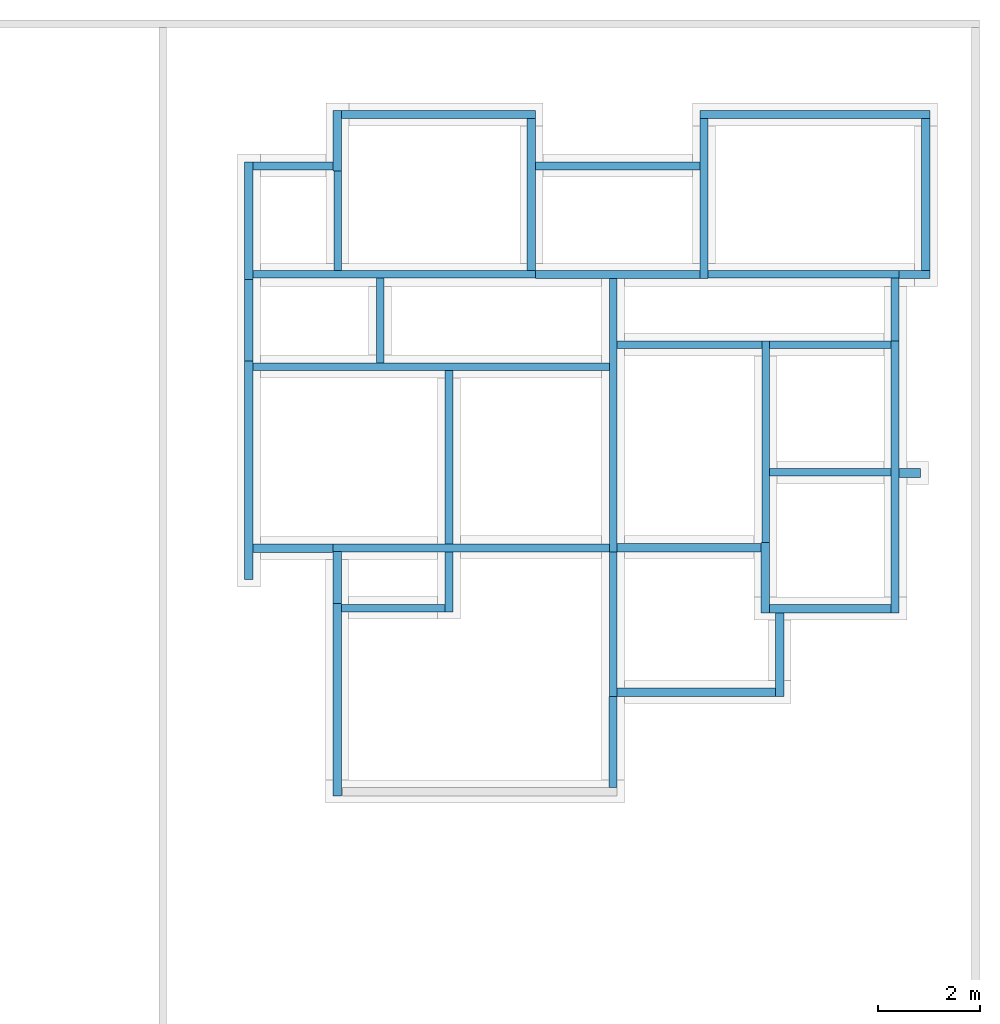
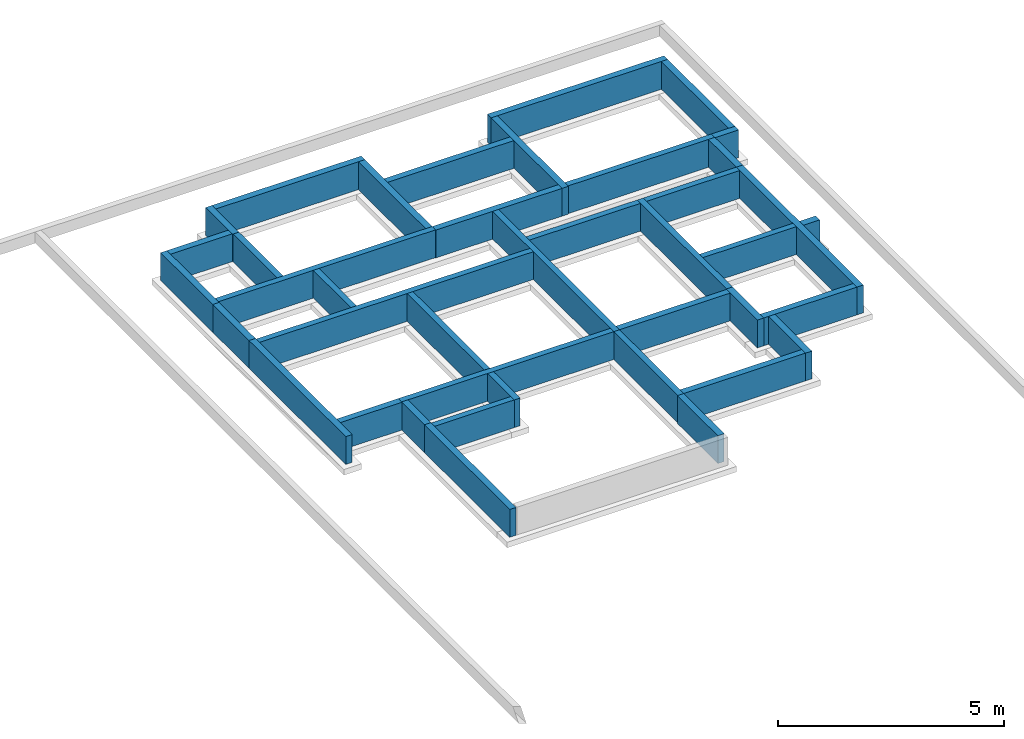
# One storey, part 2 of 2: 40 walls.
"""IFC4 building model written with IfcOpenShell, lengths in millimetres."""

from ifc_helpers import new_model, entity, si_unit, converted_unit, frame, origin_with_axes, origin_2d_with_axis, place, context, subcontext, project, spatial, indexed_curve, outline, extrude, material, layer, layer_set, layer_usage, type_object, element, save


model = new_model("IFC4")

# Units and contexts
model_context = context("Model", 3, precision=1e-05, world=origin_with_axes())
plan_context = context("Plan", 2, precision=1e-05, world=origin_2d_with_axis())
body_context = subcontext(model_context, "Body", "Model", "MODEL_VIEW")
ifc_project = project(units=[si_unit("LENGTHUNIT", "METRE", prefix="MILLI"), converted_unit("PLANEANGLEUNIT", "degree", entity("IfcReal", 0.0174532925199433), si_unit("PLANEANGLEUNIT", "RADIAN"), dimensions=[0, 0, 0, 0, 0, 0, 0]), si_unit("AREAUNIT", "SQUARE_METRE"), si_unit("VOLUMEUNIT", "CUBIC_METRE")], contexts=[model_context, plan_context])

# Site, building, storey
site_placement = place(None, origin_with_axes())
site = spatial("IfcSite", under=ifc_project, at=site_placement)
building_placement = place(site_placement, origin_with_axes())
building = spatial("IfcBuilding", under=site, at=building_placement, Name="Building")
storey_placement = place(building_placement, frame((0.0, 0.0, -900.000035762787), z_axis=(0.0, 0.0, 1.0), x_axis=(1.0, 0.0, 0.0)))
storey = spatial("IfcBuildingStorey", under=building, at=storey_placement, Name="FOUNDATION PLAN")

# Walls
ifc_material_1 = material(Name="Paint", Category="Surface Finishes")
ifc_layer_1 = layer(ifc_material_1, 1.0, Name="1-Paint", Category="Finish", Priority=4)
ifc_material_2 = material(Name="Render - Mortar", Category="Surface Finishes")
ifc_layer_2 = layer(ifc_material_2, 12.5, Name="2-Render Mortar", Category="Substrate", Priority=2)
ifc_material_3 = material(Category="Masonry")
ifc_layer_3 = layer(ifc_material_3, 150.0, Name="3", Priority=1)
ifc_layer_4 = layer(ifc_material_2, 12.5, Name="4-Plaster", Category="Substrate", Priority=2)
ifc_material_4 = material(Name="Plaster - Gypsum", Category="Surface Finishes")
ifc_layer_5 = layer(ifc_material_4, 3.0, Name="5-Plaster", Category="Finish", Priority=5)
ifc_layer_6 = layer(ifc_material_1, 1.0, Name="6-Paint", Category="Finish", Priority=5)
ifc_layer_set_1 = layer_set([ifc_layer_1, ifc_layer_2, ifc_layer_3, ifc_layer_4, ifc_layer_5, ifc_layer_6])
ifc_layer_usage_1 = layer_usage(ifc_layer_set_1, "AXIS2", "POSITIVE", 0.0)
wall_type_1 = type_object("IfcWallType", Name="WAL150HOL_2Pnt", PredefinedType="USERDEFINED", material=ifc_layer_set_1)
wall_1_placement = place(storey_placement, frame((13018.2762145996, 8947.99900054932, 1.11022302462516e-13), z_axis=(0.0, 0.0, 1.0), x_axis=(-0.999999999999803, 6.27832946520233e-07, 0.0)))
element("IfcWall", 1, at=wall_1_placement, inside=storey, type_object=wall_type_1, material=ifc_layer_usage_1, Name="WAL150HOL_2Pnt", context=body_context, shape_type="SweptSolid", body=[
    extrude(outline(indexed_curve([(0.0, 0.0), (0.0, 180.0), (420.001035814187, 180.0), (420.001035814187, 0.0), (0.0, 0.0)], self_intersect=False)), origin_with_axes(), (0.0, 0.0, 1.0), 750.000059604645),
])
ifc_material_5 = material(Category="Masonry")
ifc_layer_7 = layer(ifc_material_5, 150.0, Priority=1)
ifc_layer_set_2 = layer_set([ifc_layer_7], Name="WAL-SLD-CRE-1LYR")
ifc_layer_usage_2 = layer_usage(ifc_layer_set_2, "AXIS2", "POSITIVE", 0.0)
wall_type_2 = type_object("IfcWallType", Name="WAL150SLD_CRE", PredefinedType="SOLIDWALL", material=ifc_layer_set_2)
wall_2_placement = place(storey_placement, frame((3855.96919059753, 7463.68026733398, 1.11022302462516e-13), z_axis=(0.0, 0.0, 1.0), x_axis=(3.13916473260163e-07, 0.999999999999951, 0.0)))
element("IfcWall", 2, at=wall_2_placement, inside=storey, type_object=wall_type_2, material=ifc_layer_usage_2, Name="WAL150HOL_2Pnt", context=body_context, shape_type="SweptSolid", body=[
    extrude(outline(indexed_curve([(0.0, 0.0), (0.0, 150.0), (3404.64394879872, 150.0), (3404.64394879872, 0.0), (0.0, 0.0)], self_intersect=False)), origin_with_axes(), (0.0, 0.0, 1.0), 750.000059604645),
])
ifc_layer_usage_3 = layer_usage(ifc_layer_set_2, "AXIS2", "POSITIVE", 0.0)
wall_3_placement = place(storey_placement, frame((1523.79846572876, 14773.9343643188, 0.0), z_axis=(0.0, 0.0, 1.0), x_axis=(-6.39757843145941e-07, -0.999999999999795, 0.0)))
element("IfcWall", 3, at=wall_3_placement, inside=storey, type_object=wall_type_2, material=ifc_layer_usage_3, Name="WAL125HOL_2Pnt", context=body_context, shape_type="SweptSolid", body=[
    extrude(outline(indexed_curve([(0.0, 0.0), (0.0, 150.0), (1945.60147632466, 150.0), (1945.60147632466, 0.0), (0.0, 0.0)], self_intersect=False)), origin_with_axes(), (0.0, 0.0, 1.0), 750.000059604645),
])
ifc_layer_usage_4 = layer_usage(ifc_layer_set_2, "AXIS2", "POSITIVE", 0.0)
wall_4_placement = place(storey_placement, frame((5473.26993942261, 12828.3309936523, 0.0), z_axis=(0.0, 0.0, 1.0), x_axis=(-0.999999999999924, 3.89414367418765e-07, 0.0)))
element("IfcWall", 4, at=wall_4_placement, inside=storey, type_object=wall_type_2, material=ifc_layer_usage_4, Name="WAL150HOL_2Pnt", context=body_context, shape_type="SweptSolid", body=[
    extrude(outline(indexed_curve([(0.0, 0.0), (0.0, 150.0), (5533.79909592729, 150.0), (5533.79909592729, 0.0), (0.0, 0.0)], self_intersect=False)), origin_with_axes(), (0.0, 0.0, 1.0), 750.000059604645),
])
ifc_layer_usage_5 = layer_usage(ifc_layer_set_2, "AXIS2", "POSITIVE", 0.0)
wall_5_placement = place(storey_placement, frame((6923.27165603638, 12664.831161499, 1.11022302462516e-13), z_axis=(0.0, 0.0, 1.0), x_axis=(-1.11659494450508e-06, -0.999999999999377, 0.0)))
element("IfcWall", 5, at=wall_5_placement, inside=storey, type_object=wall_type_2, material=ifc_layer_usage_5, Name="WAL150HOL_2Pnt", context=body_context, shape_type="SweptSolid", body=[
    extrude(outline(indexed_curve([(0.0, 0.0), (0.0, 150.0), (5350.32454602854, 150.0), (5350.32454602854, 0.0), (0.0, 0.0)], self_intersect=False)), origin_with_axes(), (0.0, 0.0, 1.0), 750.000059604645),
])
ifc_layer_usage_6 = layer_usage(ifc_layer_set_2, "AXIS2", "POSITIVE", 0.0)
wall_6_placement = place(storey_placement, frame((10056.7636489868, 8798.00224304199, 1.11022302462516e-13), z_axis=(0.0, 0.0, 1.0), x_axis=(0.999999999999289, -1.19209289550697e-06, 0.0)))
element("IfcWall", 6, at=wall_6_placement, inside=storey, type_object=wall_type_2, material=ifc_layer_usage_6, Name="WAL125SLD_2Til", context=body_context, shape_type="SweptSolid", body=[
    extrude(outline(indexed_curve([(0.0, 0.0), (0.0, 150.0), (2378.01460882288, 150.0), (2378.01460882288, 0.0), (0.0, 0.0)], self_intersect=False)), origin_with_axes(), (0.0, 0.0, 1.0), 750.000059604645),
])
ifc_layer_usage_7 = layer_usage(ifc_layer_set_2, "AXIS2", "POSITIVE", 0.0)
wall_7_placement = place(storey_placement, frame((7073.27127456665, 11298.3283996582, 1.11022302462516e-13), z_axis=(0.0, 0.0, 1.0), x_axis=(0.999999999998799, -1.5497207641583e-06, 0.0)))
element("IfcWall", 7, at=wall_7_placement, inside=storey, type_object=wall_type_2, material=ifc_layer_usage_7, Name="WAL125HOL_2Pnt", context=body_context, shape_type="SweptSolid", body=[
    extrude(outline(indexed_curve([(0.0, 0.0), (0.0, 150.0), (2833.49369568034, 150.0), (2833.49369568034, 0.0), (0.0, 0.0)], self_intersect=False)), origin_with_axes(), (0.0, 0.0, 1.0), 750.000059604645),
])
ifc_layer_usage_8 = layer_usage(ifc_layer_set_2, "AXIS2", "POSITIVE", 0.0)
wall_8_placement = place(storey_placement, frame((9906.76498413086, 11448.3242034912, 1.11022302462516e-13), z_axis=(0.0, 0.0, 1.0), x_axis=(-6.39757843145941e-07, -0.999999999999795, 0.0)))
element("IfcWall", 8, at=wall_8_placement, inside=storey, type_object=wall_type_2, material=ifc_layer_usage_8, Name="WAL125SLD_IntTil", context=body_context, shape_type="SweptSolid", body=[
    extrude(outline(indexed_curve([(0.0, 0.0), (0.0, 150.0), (3953.32619377569, 150.0), (3953.32619377569, 0.0), (0.0, 0.0)], self_intersect=False)), origin_with_axes(), (0.0, 0.0, 1.0), 750.000059604645),
])
ifc_layer_usage_9 = layer_usage(ifc_layer_set_2, "AXIS2", "POSITIVE", 0.0)
wall_9_placement = place(storey_placement, frame((10056.7646026611, 11298.3226776123, 1.11022302462516e-13), z_axis=(0.0, 0.0, 1.0), x_axis=(0.999999999999744, -7.15255737304505e-07, 0.0)))
element("IfcWall", 9, at=wall_9_placement, inside=storey, type_object=wall_type_2, material=ifc_layer_usage_9, Name="WAL125SLD_IntTil", context=body_context, shape_type="SweptSolid", body=[
    extrude(outline(indexed_curve([(0.0, 0.0), (0.0, 150.0), (2378.01551115734, 150.0), (2378.01551115734, 0.0), (0.0, 0.0)], self_intersect=False)), origin_with_axes(), (0.0, 0.0, 1.0), 750.000059604645),
])
ifc_layer_usage_10 = layer_usage(ifc_layer_set_2, "AXIS2", "POSITIVE", 0.0)
wall_10_placement = place(storey_placement, frame((1673.49863052368, 6137.1808052063, 1.11022302462516e-13), z_axis=(0.0, 0.0, 1.0), x_axis=(1.0, 0.0, 0.0)))
element("IfcWall", 10, at=wall_10_placement, inside=storey, type_object=wall_type_2, material=ifc_layer_usage_10, Name="WAL125SLD_IntTil", context=body_context, shape_type="SweptSolid", body=[
    extrude(outline(indexed_curve([(0.0, 0.0), (0.0, 150.0), (2032.4709230715, 150.0), (2032.4709230715, 0.0), (0.0, 0.0)], self_intersect=False)), origin_with_axes(), (0.0, 0.0, 1.0), 750.000059604645),
])
ifc_layer_usage_11 = layer_usage(ifc_layer_set_2, "AXIS2", "POSITIVE", 0.0)
wall_11_placement = place(storey_placement, frame((6923.26593399048, 7463.68026733398, 1.11022302462516e-13), z_axis=(0.0, 0.0, 1.0), x_axis=(-0.999999999999989, 1.50995802528085e-07, 0.0)))
element("IfcWall", 11, at=wall_11_placement, inside=storey, type_object=wall_type_2, material=ifc_layer_usage_11, Name="WAL125SLD_IntTil", context=body_context, shape_type="SweptSolid", body=[
    extrude(outline(indexed_curve([(0.0, 0.0), (0.0, 150.0), (5413.26660647562, 150.0), (5413.26660647562, 0.0), (0.0, 0.0)], self_intersect=False)), origin_with_axes(), (0.0, 0.0, 1.0), 750.000059604645),
])
ifc_layer_usage_12 = layer_usage(ifc_layer_set_2, "AXIS2", "POSITIVE", 0.0)
wall_12_placement = place(storey_placement, frame((3855.96942901611, 6137.1808052063, 1.11022302462516e-13), z_axis=(0.0, 0.0, 1.0), x_axis=(3.13916473260163e-07, 0.999999999999951, 0.0)))
element("IfcWall", 12, at=wall_12_placement, inside=storey, type_object=wall_type_2, material=ifc_layer_usage_12, Name="WAL125SLD_IntTil", context=body_context, shape_type="SweptSolid", body=[
    extrude(outline(indexed_curve([(0.0, 0.0), (0.0, 150.0), (1176.49986637382, 150.0), (1176.49986637382, 0.0), (0.0, 0.0)], self_intersect=False)), origin_with_axes(), (0.0, 0.0, 1.0), 750.000059604645),
])
ifc_layer_usage_13 = layer_usage(ifc_layer_set_2, "AXIS2", "POSITIVE", 0.0)
wall_13_placement = place(storey_placement, frame((12598.2828140259, 12828.3252716064, 0.0), z_axis=(0.0, 0.0, 1.0), x_axis=(-0.999999999999625, 8.66251525621595e-07, 0.0)))
element("IfcWall", 13, at=wall_13_placement, inside=storey, type_object=wall_type_2, material=ifc_layer_usage_13, Name="WAL150HOL_2Pnt", context=body_context, shape_type="SweptSolid", body=[
    extrude(outline(indexed_curve([(0.0, 0.0), (0.0, 150.0), (3741.78406008133, 150.0), (3741.78406008133, 0.0), (0.0, 0.0)], self_intersect=False)), origin_with_axes(), (0.0, 0.0, 1.0), 750.000059604645),
])
ifc_layer_usage_14 = layer_usage(ifc_layer_set_2, "AXIS2", "POSITIVE", 0.0)
wall_14_placement = place(storey_placement, frame((-60.5289898812771, 10868.3319091797, 1.11022302462516e-13), z_axis=(0.0, 0.0, 1.0), x_axis=(0.999999999998799, -1.5497207641583e-06, 0.0)))
element("IfcWall", 14, at=wall_14_placement, inside=storey, type_object=wall_type_2, material=ifc_layer_usage_14, Name="WAL150HOL_2Pnt", context=body_context, shape_type="SweptSolid", body=[
    extrude(outline(indexed_curve([(0.0, 0.0), (0.0, 150.0), (6983.79848755728, 150.0), (6983.79848755728, 0.0), (0.0, 0.0)], self_intersect=False)), origin_with_axes(), (0.0, 0.0, 1.0), 750.000059604645),
])
ifc_layer_usage_15 = layer_usage(ifc_layer_set_2, "AXIS2", "POSITIVE", 0.0)
wall_15_placement = place(storey_placement, frame((2505.97023963928, 11018.3267593384, 0.0), z_axis=(0.0, 0.0, 1.0), x_axis=(3.13916473260163e-07, 0.999999999999951, 0.0)))
element("IfcWall", 15, at=wall_15_placement, inside=storey, type_object=wall_type_2, material=ifc_layer_usage_15, Name="WAL125SLD_IntTil", context=body_context, shape_type="SweptSolid", body=[
    extrude(outline(indexed_curve([(0.0, 0.0), (0.0, 150.0), (1660.0045886609, 150.0), (1660.0045886609, 0.0), (0.0, 0.0)], self_intersect=False)), origin_with_axes(), (0.0, 0.0, 1.0), 750.000059604645),
])
ifc_layer_usage_16 = layer_usage(ifc_layer_set_2, "AXIS2", "POSITIVE", 0.0)
wall_16_placement = place(storey_placement, frame((7073.26126098633, 4480.18360137939, 1.11022302462516e-13), z_axis=(0.0, 0.0, 1.0), x_axis=(1.5060094256097e-06, 0.999999999998866, 0.0)))
element("IfcWall", 16, at=wall_16_placement, inside=storey, type_object=wall_type_2, material=ifc_layer_usage_16, Name="WAL150HOL_2Pnt", context=body_context, shape_type="SweptSolid", body=[
    extrude(outline(indexed_curve([(0.0, 0.0), (0.0, 150.0), (2834.32389689906, 150.0), (2834.32389689906, 0.0), (0.0, 0.0)], self_intersect=False)), origin_with_axes(), (0.0, 0.0, 1.0), 750.000059604645),
])
ifc_material_6 = material(Name="Paint", Category="Surface Finishes")
ifc_layer_8 = layer(ifc_material_6, 1.0, Name="1-Paint", Category="Finish", Priority=4)
ifc_material_7 = material(Name="Render - Mortar", Category="Surface Finishes")
ifc_layer_9 = layer(ifc_material_7, 12.5, Name="2-Render Mortar", Category="Substrate", Priority=2)
ifc_layer_10 = layer(ifc_material_5, 150.0, Name="3", Priority=1)
ifc_layer_set_3 = layer_set([ifc_layer_8, ifc_layer_9, ifc_layer_10], Name="WAL-SLD-PNT-3LYR")
ifc_layer_usage_17 = layer_usage(ifc_layer_set_3, "AXIS2", "POSITIVE", 0.0)
wall_type_3 = type_object("IfcWallType", PredefinedType="SOLIDWALL", material=ifc_layer_set_3)
wall_17_placement = place(storey_placement, frame((13198.2774734497, 12828.3243179321, 0.0), z_axis=(0.0, 0.0, 1.0), x_axis=(6.71544341912371e-07, 0.999999999999775, 0.0)))
element("IfcWall", 17, at=wall_17_placement, inside=storey, type_object=wall_type_3, material=ifc_layer_usage_17, Name="WAL150HOL_2Pnt", context=body_context, shape_type="SweptSolid", body=[
    extrude(outline(indexed_curve([(0.0, 0.0), (0.0, 163.5), (2970.95592258397, 163.5), (2970.95592258397, 0.0), (0.0, 0.0)], self_intersect=False)), origin_with_axes(), (0.0, 0.0, 1.0), 750.000059604645),
])
ifc_layer_usage_18 = layer_usage(ifc_layer_set_3, "AXIS2", "POSITIVE", 0.0)
wall_18_placement = place(storey_placement, frame((1510.29884815216, 15962.7857208252, 1.11022302462516e-13), z_axis=(0.0, 0.0, 1.0), x_axis=(-6.39757843145941e-07, -0.999999999999795, 0.0)))
element("IfcWall", 18, at=wall_18_placement, inside=storey, type_object=wall_type_3, material=ifc_layer_usage_18, Name="WAL150SLD_IntTil", context=body_context, shape_type="SweptSolid", body=[
    extrude(outline(indexed_curve([(0.0, 0.0), (0.0, 163.5), (1188.85134051421, 163.5), (1188.85134051421, 0.0), (0.0, 0.0)], self_intersect=False)), origin_with_axes(), (0.0, 0.0, 1.0), 750.000059604645),
])
ifc_layer_usage_19 = layer_usage(ifc_layer_set_3, "AXIS2", "POSITIVE", 0.0)
wall_19_placement = place(storey_placement, frame((1510.29801368713, 14953.9346694946, 0.0), z_axis=(0.0, 0.0, 1.0), x_axis=(-0.999999999999924, 3.89414367418765e-07, 0.0)))
element("IfcWall", 19, at=wall_19_placement, inside=storey, type_object=wall_type_3, material=ifc_layer_usage_19, Name="WAL150HOL_2Pnt", context=body_context, shape_type="SweptSolid", body=[
    extrude(outline(indexed_curve([(0.0, 0.0), (0.0, 163.5), (1570.82650801253, 163.5), (1570.82650801253, 0.0), (0.0, 0.0)], self_intersect=False)), origin_with_axes(), (0.0, 0.0, 1.0), 750.000059604645),
])
ifc_layer_usage_20 = layer_usage(ifc_layer_set_3, "AXIS2", "POSITIVE", 0.0)
wall_20_placement = place(storey_placement, frame((12598.2828140259, 12664.8254394531, 0.0), z_axis=(0.0, 0.0, 1.0), x_axis=(0.999999999999545, -9.53674316405816e-07, 0.0)))
element("IfcWall", 20, at=wall_20_placement, inside=storey, type_object=wall_type_3, material=ifc_layer_usage_20, Name="WAL150HOL_2Pnt", context=body_context, shape_type="SweptSolid", body=[
    extrude(outline(indexed_curve([(0.0, 0.0), (0.0, 163.5), (599.994647479782, 163.5), (599.994647479782, 0.0), (0.0, 0.0)], self_intersect=False)), origin_with_axes(), (0.0, 0.0, 1.0), 750.000059604645),
])
ifc_layer_usage_21 = layer_usage(ifc_layer_set_3, "AXIS2", "POSITIVE", 0.0)
wall_21_placement = place(storey_placement, frame((5473.27184677124, 15962.7828598022, 1.11022302462516e-13), z_axis=(0.0, 0.0, 1.0), x_axis=(-0.999999999999803, 6.27832946520233e-07, 0.0)))
element("IfcWall", 21, at=wall_21_placement, inside=storey, type_object=wall_type_3, material=ifc_layer_usage_21, Name="WAL150SLD_IntTil", context=body_context, shape_type="SweptSolid", body=[
    extrude(outline(indexed_curve([(0.0, 0.0), (0.0, 163.5), (3799.47275218395, 163.5), (3799.47275218395, 0.0), (0.0, 0.0)], self_intersect=False)), origin_with_axes(), (0.0, 0.0, 1.0), 750.000059604645),
])
ifc_layer_usage_22 = layer_usage(ifc_layer_set_3, "AXIS2", "POSITIVE", 0.0)
wall_22_placement = place(storey_placement, frame((13198.2793807983, 15962.7799987793, 0.0), z_axis=(0.0, 0.0, 1.0), x_axis=(-0.999999999999803, 6.27832946520233e-07, 0.0)))
element("IfcWall", 22, at=wall_22_placement, inside=storey, type_object=wall_type_3, material=ifc_layer_usage_22, Name="WAL150HOL_2Pnt", context=body_context, shape_type="SweptSolid", body=[
    extrude(outline(indexed_curve([(0.0, 0.0), (0.0, 163.5), (4505.27856437703, 163.5), (4505.27856437703, 0.0), (0.0, 0.0)], self_intersect=False)), origin_with_axes(), (0.0, 0.0, 1.0), 750.000059604645),
])
ifc_layer_usage_23 = layer_usage(ifc_layer_set_3, "AXIS2", "POSITIVE", 0.0)
wall_23_placement = place(storey_placement, frame((-224.028423428535, 14953.9356231689, 1.11022302462516e-13), z_axis=(0.0, 0.0, 1.0), x_axis=(-2.82129974493717e-07, -0.99999999999996, 0.0)))
element("IfcWall", 23, at=wall_23_placement, inside=storey, type_object=wall_type_3, material=ifc_layer_usage_23, Name="WAL150HOL_2Pnt", context=body_context, shape_type="SweptSolid", body=[
    extrude(outline(indexed_curve([(0.0, 0.0), (0.0, 163.5), (2305.93589980149, 163.5), (2305.93589980149, 0.0), (0.0, 0.0)], self_intersect=False)), origin_with_axes(), (0.0, 0.0, 1.0), 750.000059604645),
])
ifc_layer_usage_24 = layer_usage(ifc_layer_set_3, "AXIS2", "POSITIVE", 0.0)
wall_24_placement = place(storey_placement, frame((5473.26993942261, 12828.3309936523, 0.0), z_axis=(0.0, 0.0, 1.0), x_axis=(6.71544341912371e-07, 0.999999999999775, 0.0)))
element("IfcWall", 24, at=wall_24_placement, inside=storey, type_object=wall_type_3, material=ifc_layer_usage_24, Name="WAL150SLD_IntTil.001", context=body_context, shape_type="SweptSolid", body=[
    extrude(outline(indexed_curve([(0.0, 0.0), (0.0, 163.5), (2970.95207059171, 163.5), (2970.95207059171, 0.0), (0.0, 0.0)], self_intersect=False)), origin_with_axes(), (0.0, 0.0, 1.0), 750.000059604645),
])
ifc_layer_usage_25 = layer_usage(ifc_layer_set_3, "AXIS2", "POSITIVE", 0.0)
wall_25_placement = place(storey_placement, frame((-224.029079079628, 12647.9997634888, 0.0), z_axis=(0.0, 0.0, 1.0), x_axis=(-2.82129974493717e-07, -0.99999999999996, 0.0)))
element("IfcWall", 25, at=wall_25_placement, inside=storey, type_object=wall_type_3, material=ifc_layer_usage_25, Name="WAL150SLD_IntTil", context=body_context, shape_type="SweptSolid", body=[
    extrude(outline(indexed_curve([(0.0, 0.0), (0.0, 163.5), (1599.66757718545, 163.5), (1599.66757718545, 0.0), (0.0, 0.0)], self_intersect=False)), origin_with_axes(), (0.0, 0.0, 1.0), 750.000059604645),
])
ifc_layer_usage_26 = layer_usage(ifc_layer_set_3, "AXIS2", "POSITIVE", 0.0)
wall_26_placement = place(storey_placement, frame((7073.26650619507, 7314.50653076172, 1.11022302462516e-13), z_axis=(0.0, 0.0, 1.0), x_axis=(0.999999999999886, -4.76837158203071e-07, 0.0)))
element("IfcWall", 26, at=wall_26_placement, inside=storey, type_object=wall_type_3, material=ifc_layer_usage_26, Name="WAL150HOL_2Pnt", context=body_context, shape_type="SweptSolid", body=[
    extrude(outline(indexed_curve([(0.0, 0.0), (0.0, 163.5), (2819.996316786, 163.5), (2819.996316786, 0.0), (0.0, 0.0)], self_intersect=False)), origin_with_axes(), (0.0, 0.0, 1.0), 750.000059604645),
])
ifc_layer_usage_27 = layer_usage(ifc_layer_set_3, "AXIS2", "POSITIVE", 0.0)
wall_27_placement = place(storey_placement, frame((-224.029511213303, 11048.3322143555, 0.0), z_axis=(0.0, 0.0, 1.0), x_axis=(-2.82129974493717e-07, -0.99999999999996, 0.0)))
element("IfcWall", 27, at=wall_27_placement, inside=storey, type_object=wall_type_3, material=ifc_layer_usage_27, Name="WAL150HOL_2Pnt", context=body_context, shape_type="SweptSolid", body=[
    extrude(outline(indexed_curve([(0.0, 0.0), (0.0, 163.5), (4277.32613616539, 163.5), (4277.32613616539, 0.0), (0.0, 0.0)], self_intersect=False)), origin_with_axes(), (0.0, 0.0, 1.0), 750.000059604645),
])
ifc_layer_usage_28 = layer_usage(ifc_layer_set_3, "AXIS2", "POSITIVE", 0.0)
wall_28_placement = place(storey_placement, frame((12598.2732772827, 6114.50481414795, 0.0), z_axis=(0.0, 0.0, 1.0), x_axis=(1.5060094256097e-06, 0.999999999998866, 0.0)))
element("IfcWall", 28, at=wall_28_placement, inside=storey, type_object=wall_type_3, material=ifc_layer_usage_28, Name="WAL150HOL_2Pnt", context=body_context, shape_type="SweptSolid", body=[
    extrude(outline(indexed_curve([(0.0, 0.0), (0.0, 163.5), (5333.81559258407, 163.5), (5333.81559258407, 0.0), (0.0, 0.0)], self_intersect=False)), origin_with_axes(), (0.0, 0.0, 1.0), 750.000059604645),
])
ifc_layer_usage_29 = layer_usage(ifc_layer_set_3, "AXIS2", "POSITIVE", 0.0)
wall_29_placement = place(storey_placement, frame((12598.2809066772, 11448.3203887939, 0.0), z_axis=(0.0, 0.0, 1.0), x_axis=(1.5060094256097e-06, 0.999999999998866, 0.0)))
element("IfcWall", 29, at=wall_29_placement, inside=storey, type_object=wall_type_3, material=ifc_layer_usage_29, Name="WAL150HOL_2Pnt", context=body_context, shape_type="SweptSolid", body=[
    extrude(outline(indexed_curve([(0.0, 0.0), (0.0, 163.5), (1230.0043107569, 163.5), (1230.0043107569, 0.0), (0.0, 0.0)], self_intersect=False)), origin_with_axes(), (0.0, 0.0, 1.0), 750.000059604645),
])
ifc_layer_usage_30 = layer_usage(ifc_layer_set_3, "AXIS2", "POSITIVE", 0.0)
wall_30_placement = place(storey_placement, frame((1509.99927520752, 6300.18091201782, 0.0), z_axis=(0.0, 0.0, 1.0), x_axis=(-6.39757843145941e-07, -0.999999999999795, 0.0)))
element("IfcWall", 30, at=wall_30_placement, inside=storey, type_object=wall_type_3, material=ifc_layer_usage_30, Name="WAL150HOL_2Pnt", context=body_context, shape_type="SweptSolid", body=[
    extrude(outline(indexed_curve([(0.0, 0.0), (0.0, 163.5), (3769.99951552405, 163.5), (3769.99951552405, 0.0), (0.0, 0.0)], self_intersect=False)), origin_with_axes(), (0.0, 0.0, 1.0), 750.000059604645),
])
ifc_layer_usage_31 = layer_usage(ifc_layer_set_3, "AXIS2", "POSITIVE", 0.0)
wall_31_placement = place(storey_placement, frame((9893.26286315918, 7494.50492858887, 0.0), z_axis=(0.0, 0.0, 1.0), x_axis=(-6.39757843145941e-07, -0.999999999999795, 0.0)))
element("IfcWall", 31, at=wall_31_placement, inside=storey, type_object=wall_type_3, material=ifc_layer_usage_31, Name="WAL150SLD_IntTil", context=body_context, shape_type="SweptSolid", body=[
    extrude(outline(indexed_curve([(0.0, 0.0), (0.0, 163.5), (1379.9991761084, 163.5), (1379.9991761084, 0.0), (0.0, 0.0)], self_intersect=False)), origin_with_axes(), (0.0, 0.0, 1.0), 750.000059604645),
])
ifc_layer_usage_32 = layer_usage(ifc_layer_set_3, "AXIS2", "POSITIVE", 0.0)
wall_32_placement = place(storey_placement, frame((1509.99987125397, 7317.00086593628, 0.0), z_axis=(0.0, 0.0, 1.0), x_axis=(-6.39757843145941e-07, -0.999999999999795, 0.0)))
element("IfcWall", 32, at=wall_32_placement, inside=storey, type_object=wall_type_3, material=ifc_layer_usage_32, Name="WAL150SLD_IntTil", context=body_context, shape_type="SweptSolid", body=[
    extrude(outline(indexed_curve([(0.0, 0.0), (0.0, 163.5), (1016.81994054079, 163.5), (1016.81994054079, 0.0), (0.0, 0.0)], self_intersect=False)), origin_with_axes(), (0.0, 0.0, 1.0), 750.000059604645),
])
ifc_layer_usage_33 = layer_usage(ifc_layer_set_3, "AXIS2", "POSITIVE", 0.0)
wall_33_placement = place(storey_placement, frame((8693.00079345703, 15799.2830276489, 1.11022302462516e-13), z_axis=(0.0, 0.0, 1.0), x_axis=(-6.39757843145941e-07, -0.999999999999795, 0.0)))
element("IfcWall", 33, at=wall_33_placement, inside=storey, type_object=wall_type_3, material=ifc_layer_usage_33, Name="WAL150HOL_2Pnt", context=body_context, shape_type="SweptSolid", body=[
    extrude(outline(indexed_curve([(0.0, 0.0), (0.0, 163.5), (3134.45377878453, 163.5), (3134.45377878453, 0.0), (0.0, 0.0)], self_intersect=False)), origin_with_axes(), (0.0, 0.0, 1.0), 750.000059604645),
])
ifc_layer_usage_34 = layer_usage(ifc_layer_set_3, "AXIS2", "POSITIVE", 0.0)
wall_34_placement = place(storey_placement, frame((-60.5304539203644, 7300.18138885498, 1.11022302462516e-13), z_axis=(0.0, 0.0, 1.0), x_axis=(1.0, 0.0, 0.0)))
element("IfcWall", 34, at=wall_34_placement, inside=storey, type_object=wall_type_3, material=ifc_layer_usage_34, Name="WAL150HOL_2Pnt", context=body_context, shape_type="SweptSolid", body=[
    extrude(outline(indexed_curve([(0.0, 0.0), (0.0, 163.5), (1570.53043504316, 163.5), (1570.53043504316, 0.0), (0.0, 0.0)], self_intersect=False)), origin_with_axes(), (0.0, 0.0, 1.0), 750.000059604645),
])
ifc_layer_usage_35 = layer_usage(ifc_layer_set_3, "AXIS2", "POSITIVE", 0.0)
wall_35_placement = place(storey_placement, frame((8692.9988861084, 12828.3290863037, 0.0), z_axis=(0.0, 0.0, 1.0), x_axis=(-0.999999999999625, 8.66251525621595e-07, 0.0)))
element("IfcWall", 35, at=wall_35_placement, inside=storey, type_object=wall_type_3, material=ifc_layer_usage_35, Name="WAL150HOL_2Pnt", context=body_context, shape_type="SweptSolid", body=[
    extrude(outline(indexed_curve([(0.0, 0.0), (0.0, 163.5), (3219.7293763744, 163.5), (3219.7293763744, 0.0), (0.0, 0.0)], self_intersect=False)), origin_with_axes(), (0.0, 0.0, 1.0), 750.000059604645),
])
ifc_layer_usage_36 = layer_usage(ifc_layer_set_3, "AXIS2", "POSITIVE", 0.0)
wall_36_placement = place(storey_placement, frame((10056.7626953125, 6114.50481414795, 0.0), z_axis=(0.0, 0.0, 1.0), x_axis=(1.0, 0.0, 0.0)))
element("IfcWall", 36, at=wall_36_placement, inside=storey, type_object=wall_type_3, material=ifc_layer_usage_36, Name="WAL150SLD_IntTil", context=body_context, shape_type="SweptSolid", body=[
    extrude(outline(indexed_curve([(0.0, 0.0), (0.0, 163.5), (2378.01170129359, 163.5), (2378.01170129359, 0.0), (0.0, 0.0)], self_intersect=False)), origin_with_axes(), (0.0, 0.0, 1.0), 750.000059604645),
])
ifc_layer_usage_37 = layer_usage(ifc_layer_set_3, "AXIS2", "POSITIVE", 0.0)
wall_37_placement = place(storey_placement, frame((7073.25839996338, 2693.68028640747, 1.11022302462516e-13), z_axis=(0.0, 0.0, 1.0), x_axis=(1.5060094256097e-06, 0.999999999998866, 0.0)))
element("IfcWall", 37, at=wall_37_placement, inside=storey, type_object=wall_type_3, material=ifc_layer_usage_37, Name="WAL150HOL_2Pnt", context=body_context, shape_type="SweptSolid", body=[
    extrude(outline(indexed_curve([(0.0, 0.0), (0.0, 163.5), (1786.50332321228, 163.5), (1786.50332321228, 0.0), (0.0, 0.0)], self_intersect=False)), origin_with_axes(), (0.0, 0.0, 1.0), 750.000059604645),
])
ifc_layer_usage_38 = layer_usage(ifc_layer_set_3, "AXIS2", "POSITIVE", 0.0)
wall_38_placement = place(storey_placement, frame((7073.26126098633, 4480.1812171936, 1.11022302462516e-13), z_axis=(0.0, 0.0, 1.0), x_axis=(1.0, 0.0, 0.0)))
element("IfcWall", 38, at=wall_38_placement, inside=storey, type_object=wall_type_3, material=ifc_layer_usage_38, Name="WAL150SLD", context=body_context, shape_type="SweptSolid", body=[
    extrude(outline(indexed_curve([(0.0, 0.0), (0.0, 163.5), (3106.50057175387, 163.5), (3106.50057175387, 0.0), (0.0, 0.0)], self_intersect=False)), origin_with_axes(), (0.0, 0.0, 1.0), 750.000059604645),
])
ifc_layer_usage_39 = layer_usage(ifc_layer_set_3, "AXIS2", "POSITIVE", 0.0)
wall_39_placement = place(storey_placement, frame((10343.26171875, 4480.1812171936, 1.11022302462516e-13), z_axis=(0.0, 0.0, 1.0), x_axis=(1.5060094256097e-06, 0.999999999998866, 0.0)))
element("IfcWall", 39, at=wall_39_placement, inside=storey, type_object=wall_type_3, material=ifc_layer_usage_39, Name="WAL150SLD", context=body_context, shape_type="SweptSolid", body=[
    extrude(outline(indexed_curve([(0.0, 0.0), (0.0, 163.5), (1634.3254855031, 163.5), (1634.3254855031, 0.0), (0.0, 0.0)], self_intersect=False)), origin_with_axes(), (0.0, 0.0, 1.0), 750.000059604645),
])
ifc_layer_usage_40 = layer_usage(ifc_layer_set_3, "AXIS2", "POSITIVE", 0.0)
wall_40_placement = place(storey_placement, frame((8692.99983978271, 14953.9346694946, 1.11022302462516e-13), z_axis=(0.0, 0.0, 1.0), x_axis=(-0.999999999999924, 3.89414367418765e-07, 0.0)))
element("IfcWall", 40, at=wall_40_placement, inside=storey, type_object=wall_type_3, material=ifc_layer_usage_40, Name="WAL150HOL_2Pnt", context=body_context, shape_type="SweptSolid", body=[
    extrude(outline(indexed_curve([(0.0, 0.0), (0.0, 163.5), (3219.72848778244, 163.5), (3219.72848778244, 0.0), (0.0, 0.0)], self_intersect=False)), origin_with_axes(), (0.0, 0.0, 1.0), 750.000059604645),
])

save(model, "model.ifc")
